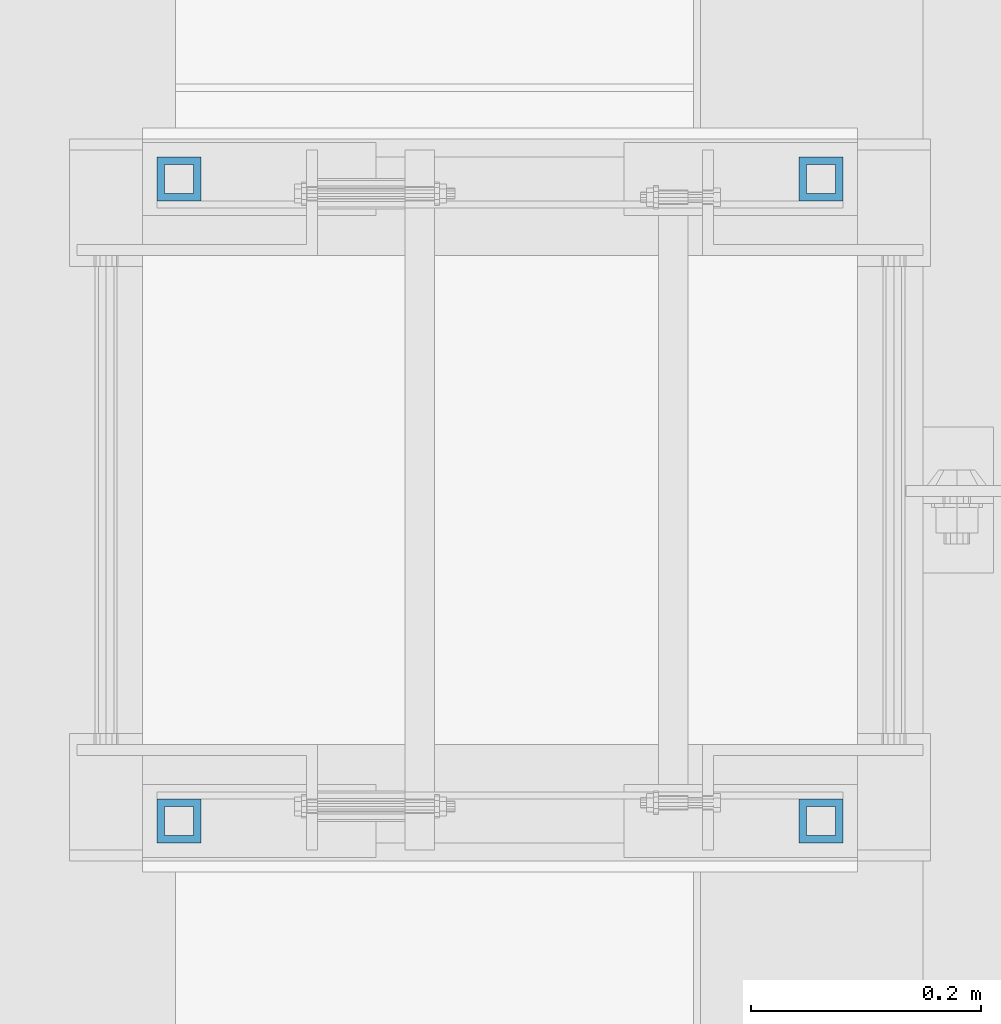
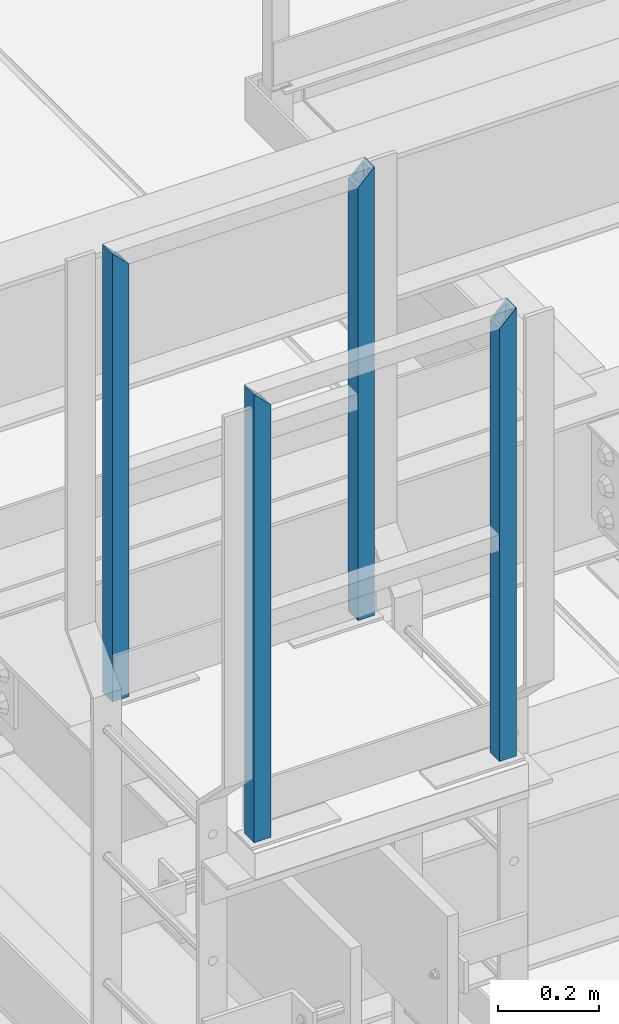
# One storey, part 1291 of 3843: 4 columns, 2 elements without a shape of their own.
"""IFC2X3 building model written with IfcOpenShell, lengths in millimetres."""

from ifc_helpers import new_model, si_unit, frame, origin_with_axes, place, context, subcontext, project, spatial, faceted_brep, material, type_object, element, aggregate, save


model = new_model("IFC2X3")

# Units and contexts
model_context = context("Model", 3, precision=1e-05, world=origin_with_axes())
body_context = subcontext(model_context, "Body", "Model", "MODEL_VIEW")
ifc_project = project(units=[si_unit("LENGTHUNIT", "METRE", prefix="MILLI"), si_unit("AREAUNIT", "SQUARE_METRE"), si_unit("VOLUMEUNIT", "CUBIC_METRE"), si_unit("MASSUNIT", "GRAM", prefix="KILO"), si_unit("TIMEUNIT", "SECOND"), si_unit("PLANEANGLEUNIT", "RADIAN"), si_unit("SOLIDANGLEUNIT", "STERADIAN"), si_unit("THERMODYNAMICTEMPERATUREUNIT", "DEGREE_CELSIUS"), si_unit("LUMINOUSINTENSITYUNIT", "LUMEN")], contexts=[model_context])

# Site, building, storey
site_placement = place(None, origin_with_axes())
site = spatial("IfcSite", under=ifc_project, at=site_placement, CompositionType="ELEMENT")
building_placement = place(site_placement, origin_with_axes())
building = spatial("IfcBuilding", under=site, at=building_placement, Name="Undefined", CompositionType="ELEMENT")
storey_placement = place(building_placement, origin_with_axes())
storey = spatial("IfcBuildingStorey", under=building, at=storey_placement, Name="Undefined", CompositionType="ELEMENT", Elevation=0.0)

# Assembly, columns
assembly_1_placement = place(storey_placement, origin_with_axes())
assembly_1 = element("IfcElementAssembly", 1, at=assembly_1_placement, inside=storey, Name="RAIL", AssemblyPlace="NOTDEFINED", PredefinedType="RIGID_FRAME")
ifc_material = material()
column_type = type_object("IfcColumnType", Name="HSS1-1/2X1-1/2X1/4", PredefinedType="NOTDEFINED")
column_1_placement = place(assembly_1_placement, frame((48828.325000765, 17932.4, 44113.45), z_axis=(-1.0, 0.0, 0.0), x_axis=(0.0, 0.0, 1.0)))
column_1 = element("IfcColumn", 2, at=column_1_placement, type_object=column_type, material=ifc_material, Name="POST", ObjectType="HSS1-1/2X1-1/2X1/4", context=body_context, shape_type="Brep", body=[
    faceted_brep([(6.34999999999854, 12.6999993299978, -12.6999993299978), (6.34999999999854, -12.6999993299978, -12.6999993299978), (1079.49999933128, -12.6999993300014, -12.6999993299978), (1079.49999933128, 12.6999993300014, -12.6999993299978), (6.34999999999854, -12.6999993299978, 12.6999993299978), (1054.10000067129, -12.6999993300014, 12.6999993299978), (6.34999999999854, 12.6999993299978, 12.6999993299978), (1054.10000067129, 12.6999993300014, 12.6999993299978), (6.34999999999854, 19.0499992350015, -19.0499992349942), (6.34999999999854, 19.0499992350015, 19.0499992349942), (1047.75000076629, 19.0499992350015, 19.0499992349942), (1085.84999923629, 19.0499992350015, -19.0499992349942), (6.34999999999854, -19.0499992350015, 19.0499992349942), (1047.75000076629, -19.0499992350015, 19.0499992349942), (6.34999999999854, -19.0499992350015, -19.0499992349942), (1085.84999923629, -19.0499992350015, -19.0499992349942)], [[[0, 1, 2, 3]], [[1, 4, 5, 2]], [[4, 6, 7, 5]], [[6, 0, 3, 7]], [[8, 9, 10, 11]], [[9, 12, 13, 10]], [[12, 14, 15, 13]], [[14, 8, 11, 15]], [[13, 15, 11, 10], [5, 7, 3, 2]], [[14, 12, 9, 8], [6, 4, 1, 0]]]),
])
column_2_placement = place(assembly_1_placement, frame((48269.524987793, 17932.4, 44113.45), z_axis=(-1.0, 0.0, 0.0), x_axis=(0.0, 0.0, 1.0)))
column_2 = element("IfcColumn", 3, at=column_2_placement, type_object=column_type, material=ifc_material, Name="POST", ObjectType="HSS1-1/2X1-1/2X1/4", context=body_context, shape_type="Brep", body=[
    faceted_brep([(6.34999999999854, 12.6999993299978, -12.6999993299978), (6.34999999999854, -12.6999993299978, -12.6999993299978), (1054.10000067001, -12.6999993300014, -12.6999993299978), (1054.10000067001, 12.6999993300014, -12.6999993299978), (6.34999999999854, -12.6999993299978, 12.6999993299978), (1079.49999933, -12.6999993300014, 12.6999993299978), (6.34999999999854, 12.6999993299978, 12.6999993299978), (1079.49999933, 12.6999993300014, 12.6999993299978), (6.34999999999854, 19.0499992350015, -19.0499992349942), (6.34999999999854, 19.0499992350015, 19.0499992349942), (1085.849999235, 19.0499992350015, 19.0499992350015), (1047.750000765, 19.0499992350015, -19.0499992350015), (6.34999999999854, -19.0499992350015, 19.0499992349942), (1085.849999235, -19.0499992350015, 19.0499992350015), (6.34999999999854, -19.0499992350015, -19.0499992349942), (1047.750000765, -19.0499992350015, -19.0499992350015)], [[[0, 1, 2, 3]], [[1, 4, 5, 2]], [[4, 6, 7, 5]], [[6, 0, 3, 7]], [[8, 9, 10, 11]], [[9, 12, 13, 10]], [[12, 14, 15, 13]], [[14, 8, 11, 15]], [[13, 15, 11, 10], [5, 7, 3, 2]], [[14, 12, 9, 8], [6, 4, 1, 0]]]),
])
aggregate(assembly_1, [column_1, column_2])

assembly_2_placement = place(storey_placement, origin_with_axes())
assembly_2 = element("IfcElementAssembly", 4, at=assembly_2_placement, inside=storey, Name="RAIL", AssemblyPlace="NOTDEFINED", PredefinedType="RIGID_FRAME")
column_3_placement = place(assembly_2_placement, frame((48828.325000765, 17373.6, 44113.45), z_axis=(-1.0, 0.0, 0.0), x_axis=(0.0, 0.0, 1.0)))
column_3 = element("IfcColumn", 5, at=column_3_placement, type_object=column_type, material=ifc_material, Name="POST", ObjectType="HSS1-1/2X1-1/2X1/4", context=body_context, shape_type="Brep", body=[
    faceted_brep([(6.34999999999854, 12.6999993299978, -12.6999993299978), (6.34999999999854, -12.6999993299978, -12.6999993299978), (1079.49999933128, -12.6999993300014, -12.6999993299978), (1079.49999933128, 12.6999993300014, -12.6999993299978), (6.34999999999854, -12.6999993299978, 12.6999993299978), (1054.10000067129, -12.6999993300014, 12.6999993299978), (6.34999999999854, 12.6999993299978, 12.6999993299978), (1054.10000067129, 12.6999993300014, 12.6999993299978), (6.34999999999854, 19.0499992350015, -19.0499992349942), (6.34999999999854, 19.0499992350015, 19.0499992349942), (1047.75000076629, 19.0499992350015, 19.0499992349942), (1085.84999923629, 19.0499992350015, -19.0499992349942), (6.34999999999854, -19.0499992350015, 19.0499992349942), (1047.75000076629, -19.0499992350015, 19.0499992349942), (6.34999999999854, -19.0499992350015, -19.0499992349942), (1085.84999923629, -19.0499992350015, -19.0499992349942)], [[[0, 1, 2, 3]], [[1, 4, 5, 2]], [[4, 6, 7, 5]], [[6, 0, 3, 7]], [[8, 9, 10, 11]], [[9, 12, 13, 10]], [[12, 14, 15, 13]], [[14, 8, 11, 15]], [[13, 15, 11, 10], [5, 7, 3, 2]], [[14, 12, 9, 8], [6, 4, 1, 0]]]),
])
column_4_placement = place(assembly_2_placement, frame((48269.524987793, 17373.6, 44113.45), z_axis=(-1.0, 0.0, 0.0), x_axis=(0.0, 0.0, 1.0)))
column_4 = element("IfcColumn", 6, at=column_4_placement, type_object=column_type, material=ifc_material, Name="POST", ObjectType="HSS1-1/2X1-1/2X1/4", context=body_context, shape_type="Brep", body=[
    faceted_brep([(6.34999999999854, 12.6999993299978, -12.6999993299978), (6.34999999999854, -12.6999993299978, -12.6999993299978), (1054.10000067001, -12.6999993300014, -12.6999993299978), (1054.10000067001, 12.6999993300014, -12.6999993299978), (6.34999999999854, -12.6999993299978, 12.6999993299978), (1079.49999933, -12.6999993300014, 12.6999993299978), (6.34999999999854, 12.6999993299978, 12.6999993299978), (1079.49999933, 12.6999993300014, 12.6999993299978), (6.34999999999854, 19.0499992350015, -19.0499992349942), (6.34999999999854, 19.0499992350015, 19.0499992349942), (1085.849999235, 19.0499992350015, 19.0499992350015), (1047.750000765, 19.0499992350015, -19.0499992350015), (6.34999999999854, -19.0499992350015, 19.0499992349942), (1085.849999235, -19.0499992350015, 19.0499992350015), (6.34999999999854, -19.0499992350015, -19.0499992349942), (1047.750000765, -19.0499992350015, -19.0499992350015)], [[[0, 1, 2, 3]], [[1, 4, 5, 2]], [[4, 6, 7, 5]], [[6, 0, 3, 7]], [[8, 9, 10, 11]], [[9, 12, 13, 10]], [[12, 14, 15, 13]], [[14, 8, 11, 15]], [[13, 15, 11, 10], [5, 7, 3, 2]], [[14, 12, 9, 8], [6, 4, 1, 0]]]),
])
aggregate(assembly_2, [column_3, column_4])

save(model, "model.ifc")
